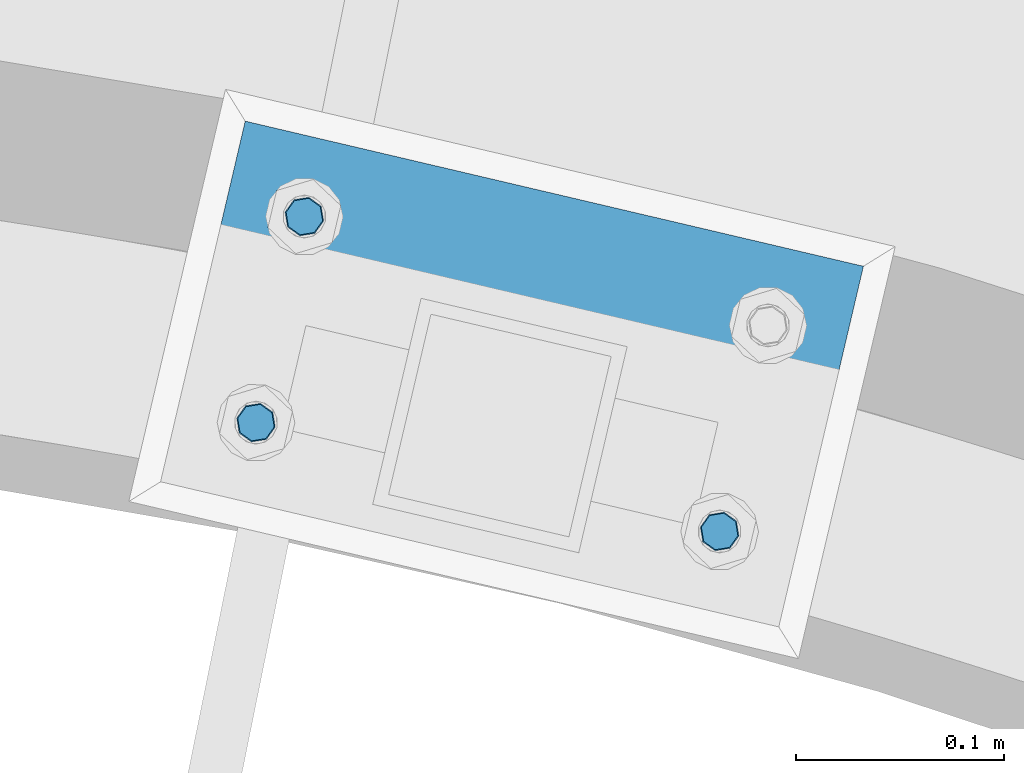
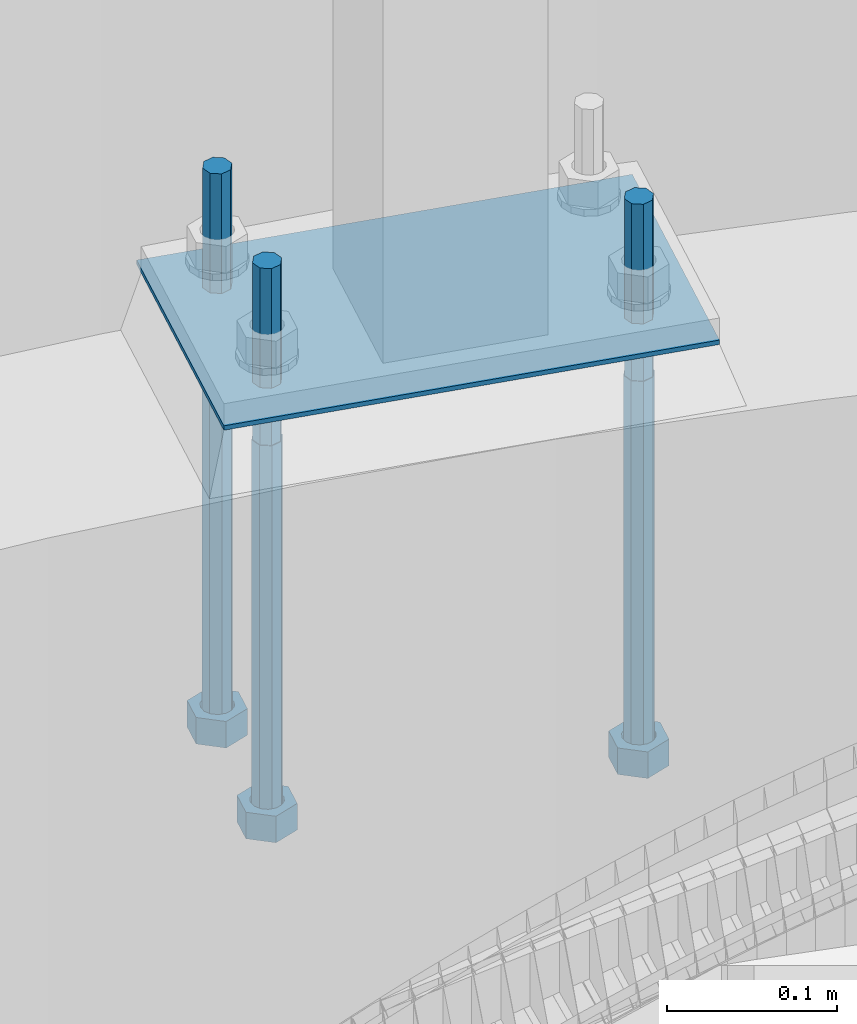
# One storey, part 517 of 975: 4 beams.
"""IFC2X3 building model written with IfcOpenShell, lengths in millimetres."""

from ifc_helpers import new_model, si_unit, frame, origin_with_axes, place, context, subcontext, project, spatial, faceted_brep, material, type_object, element, save


model = new_model("IFC2X3")

# Units and contexts
model_context = context("Model", 3, precision=1e-05, world=origin_with_axes())
body_context = subcontext(model_context, "Body", "Model", "MODEL_VIEW")
ifc_project = project(units=[si_unit("LENGTHUNIT", "METRE", prefix="MILLI"), si_unit("AREAUNIT", "SQUARE_METRE"), si_unit("VOLUMEUNIT", "CUBIC_METRE"), si_unit("MASSUNIT", "GRAM", prefix="KILO"), si_unit("TIMEUNIT", "SECOND"), si_unit("PLANEANGLEUNIT", "RADIAN"), si_unit("SOLIDANGLEUNIT", "STERADIAN"), si_unit("THERMODYNAMICTEMPERATUREUNIT", "DEGREE_CELSIUS"), si_unit("LUMINOUSINTENSITYUNIT", "LUMEN")], contexts=[model_context])

# Site, building, storey
site_placement = place(None, origin_with_axes())
site = spatial("IfcSite", under=ifc_project, at=site_placement, CompositionType="ELEMENT")
building_placement = place(site_placement, origin_with_axes())
building = spatial("IfcBuilding", under=site, at=building_placement, Name="Undefined", CompositionType="ELEMENT")
storey_placement = place(building_placement, origin_with_axes())
storey = spatial("IfcBuildingStorey", under=building, at=storey_placement, Name="Undefined", CompositionType="ELEMENT", Elevation=0.0)

# Beams
ifc_material_1 = material(Name="STEEL/F1554-36")
beam_type_1 = type_object("IfcBeamType", PredefinedType="NOTDEFINED")
beam_1_placement = place(storey_placement, frame((35592.3662910119, 6558.1059971626, 1371.6), z_axis=(0.973539033329667, -0.228520788077446, 0.0), x_axis=(0.0, 0.0, -1.0)))
element("IfcBeam", 1, at=beam_1_placement, inside=storey, type_object=beam_type_1, material=ifc_material_1, Name="HEADED_ANCHOR_BOLT", context=body_context, shape_type="Brep", body=[
    faceted_brep([(260.34375, -9.13000011445183, 15.8100004195221), (260.34375, -18.2600002289691, -1.45519152283669e-11), (279.393749999999, -18.2600002289691, -1.45519152283669e-11), (279.393749999999, -9.13000011445183, 15.8100004195221), (260.34375, 9.13000011451732, 15.8100004195403), (279.393749999999, 9.13000011451732, 15.8100004195403), (260.34375, 18.2600002289728, 1.81898940354586e-11), (279.393749999999, 18.2600002289728, 1.81898940354586e-11), (260.34375, 9.13000011445547, -15.8100004195221), (279.393749999999, 9.13000011445547, -15.8100004195221), (260.34375, -9.13000011451732, -15.8100004195367), (279.393749999999, -9.13000011451732, -15.8100004195367), (260.34375, -4.47768005528269, 9.29799844174704), (260.34375, -8.06850066050174, 6.43441456486471), (260.34375, -10.0612557562381, 2.29641597050068), (260.34375, -10.0612557562454, -2.29641597051523), (260.34375, -8.06850066052721, -6.43441456487926), (260.34375, -4.47768005531907, -9.29799844175068), (260.34375, -1.81898940354586e-11, -10.319999694766), (260.34375, 4.47768005528633, -9.2979984417434), (260.34375, 8.06850066050174, -6.43441456486471), (260.34375, 10.0612557562381, -2.29641597050068), (260.34375, 10.0612557562454, 2.29641597051886), (260.34375, 8.06850066052357, 6.4344145648829), (260.34375, 4.47768005532271, 9.29799844175432), (260.34375, 2.18278728425503e-11, 10.3199996947696), (279.393749999999, 2.18278728425503e-11, 10.3199996947696), (279.393749999999, -4.47768005528269, 9.29799844174704), (279.393749999999, -8.06850066050174, 6.43441456486471), (279.393749999999, -10.0612557562381, 2.29641597050068), (279.393749999999, -10.0612557562454, -2.29641597051523), (279.393749999999, -8.06850066052721, -6.43441456487926), (279.393749999999, -4.47768005531907, -9.29799844175068), (279.393749999999, -1.81898940354586e-11, -10.319999694766), (279.393749999999, 4.47768005528633, -9.2979984417434), (279.393749999999, 8.06850066050174, -6.43441456486471), (279.393749999999, 10.0612557562381, -2.29641597050068), (279.393749999999, 10.0612557562454, 2.29641597051886), (279.393749999999, 8.06850066052357, 6.4344145648829), (279.393749999999, 4.47768005532271, 9.29799844175432), (0.0, -6.73519209080223, 6.73519209080186), (0.0, -9.52499999999964, 0.0), (279.400000000001, -9.52499999999782, -3.63797880709171e-12), (279.400000000001, -6.73519209079313, 6.73519209079313), (-9.87109982941227e-13, -1.20792265079217e-13, 9.52499961853027), (279.400000000001, 1.09139364212751e-11, 9.52499999999054), (0.0, 6.73519209080223, 6.73519209080186), (279.400000000001, 6.73519209081132, 6.73519209079677), (0.0, 9.52499999999964, 0.0), (279.400000000001, 9.52500000000146, 3.63797880709171e-12), (0.0, 6.73519209080223, -6.73519209080186), (279.400000000001, 6.73519209079677, -6.73519209079313), (2.95075507493764e-12, -1.20792265079217e-13, -9.52499961853027), (279.400000000001, -1.09139364212751e-11, -9.5249999999869), (-126.99791499542, -6.36396103070001, 6.3639610306418), (-126.99791499542, 1.81898940354586e-11, 8.99999999995271), (-126.99791499542, 6.36396103072184, 6.36396103065272), (-126.99791499542, 9.00000000004366, 1.09139364212751e-11), (-126.99791499542, 6.36396103069637, -6.3639610306418), (-126.99791499542, -1.81898940354586e-11, -8.99999999995271), (-126.99791499542, -6.36396103072184, -6.36396103064908), (-126.99791499542, -9.00000000004002, -7.27595761418343e-12), (0.0149743263646087, 6.36396103067818, -6.36396103067909), (0.0149743263646087, 0.0, -9.0), (0.0149743263646087, -6.36396103067818, -6.36396103067909), (0.0149743263987148, -8.9999995411581, -1.00796984270346e-06), (0.0149743263646087, -6.36396103067818, 6.36396103067909), (0.0149743263646087, 0.0, 9.0), (0.0149743263646087, 6.36396103067818, 6.36396103067909), (0.0149743263987148, 9.0000004588419, -1.00796984270346e-06), (0.0, -6.73519209080223, -6.73519209080186), (279.400000000001, -6.73519209080769, -6.73519209079677)], [[[0, 1, 2, 3]], [[4, 0, 3, 5]], [[6, 4, 5, 7]], [[8, 6, 7, 9]], [[10, 8, 9, 11]], [[0, 4, 6, 8, 10, 1], [12, 13, 14, 15, 16, 17, 18, 19, 20, 21, 22, 23, 24, 25]], [[12, 25, 26, 27]], [[13, 12, 27, 28]], [[14, 13, 28, 29]], [[15, 14, 29, 30]], [[16, 15, 30, 31]], [[17, 16, 31, 32]], [[18, 17, 32, 33]], [[19, 18, 33, 34]], [[20, 19, 34, 35]], [[21, 20, 35, 36]], [[22, 21, 36, 37]], [[23, 22, 37, 38]], [[24, 23, 38, 39]], [[25, 24, 39, 26]], [[9, 7, 5, 3, 2, 11], [38, 37, 36, 35, 34, 33, 32, 31, 30, 29, 28, 27, 26, 39]], [[1, 10, 11, 2]], [[40, 41, 42, 43]], [[44, 40, 43, 45]], [[46, 44, 45, 47]], [[48, 46, 47, 49]], [[50, 48, 49, 51]], [[52, 50, 51, 53]], [[54, 55, 56, 57, 58, 59, 60, 61]], [[59, 58, 62, 63]], [[60, 59, 63, 64]], [[61, 60, 64, 65]], [[54, 61, 65, 66]], [[55, 54, 66, 67]], [[56, 55, 67, 68]], [[57, 56, 68, 69]], [[58, 57, 69, 62]], [[40, 44, 46, 48, 50, 52, 70, 41], [68, 67, 66, 65, 64, 63, 62, 69]], [[41, 70, 71, 42]], [[53, 51, 49, 47, 45, 43, 42, 71]], [[70, 52, 53, 71]]]),
])
beam_2_placement = place(storey_placement, frame((35369.8152679914, 6610.34584931771, 1371.6), z_axis=(0.973539033329667, -0.228520788077446, 0.0), x_axis=(0.0, 0.0, -1.0)))
element("IfcBeam", 2, at=beam_2_placement, inside=storey, type_object=beam_type_1, material=ifc_material_1, Name="HEADED_ANCHOR_BOLT", context=body_context, shape_type="Brep", body=[
    faceted_brep([(260.34375, -9.13000011445183, 15.8100004195221), (260.34375, -18.2600002289691, -1.45519152283669e-11), (279.393749999999, -18.2600002289691, -1.45519152283669e-11), (279.393749999999, -9.13000011445183, 15.8100004195221), (260.34375, 9.13000011451732, 15.8100004195403), (279.393749999999, 9.13000011451732, 15.8100004195403), (260.34375, 18.2600002289728, 1.81898940354586e-11), (279.393749999999, 18.2600002289728, 1.81898940354586e-11), (260.34375, 9.13000011445547, -15.8100004195221), (279.393749999999, 9.13000011445547, -15.8100004195221), (260.34375, -9.13000011451732, -15.8100004195367), (279.393749999999, -9.13000011451732, -15.8100004195367), (260.34375, -4.47768005528269, 9.29799844174704), (260.34375, -8.06850066050174, 6.43441456486471), (260.34375, -10.0612557562381, 2.29641597050068), (260.34375, -10.0612557562454, -2.29641597051523), (260.34375, -8.06850066052721, -6.43441456487926), (260.34375, -4.47768005531907, -9.29799844175068), (260.34375, -1.81898940354586e-11, -10.319999694766), (260.34375, 4.47768005528633, -9.2979984417434), (260.34375, 8.06850066050174, -6.43441456486471), (260.34375, 10.0612557562381, -2.29641597050068), (260.34375, 10.0612557562454, 2.29641597051886), (260.34375, 8.06850066052357, 6.4344145648829), (260.34375, 4.47768005532271, 9.29799844175432), (260.34375, 2.18278728425503e-11, 10.3199996947696), (279.393749999999, 2.18278728425503e-11, 10.3199996947696), (279.393749999999, -4.47768005528269, 9.29799844174704), (279.393749999999, -8.06850066050174, 6.43441456486471), (279.393749999999, -10.0612557562381, 2.29641597050068), (279.393749999999, -10.0612557562454, -2.29641597051523), (279.393749999999, -8.06850066052721, -6.43441456487926), (279.393749999999, -4.47768005531907, -9.29799844175068), (279.393749999999, -1.81898940354586e-11, -10.319999694766), (279.393749999999, 4.47768005528633, -9.2979984417434), (279.393749999999, 8.06850066050174, -6.43441456486471), (279.393749999999, 10.0612557562381, -2.29641597050068), (279.393749999999, 10.0612557562454, 2.29641597051886), (279.393749999999, 8.06850066052357, 6.4344145648829), (279.393749999999, 4.47768005532271, 9.29799844175432), (0.0, -6.73519209080223, 6.73519209080186), (0.0, -9.52499999999964, 0.0), (279.400000000001, -9.52499999999782, -3.63797880709171e-12), (279.400000000001, -6.73519209079313, 6.73519209079313), (-9.87109982941227e-13, -1.20792265079217e-13, 9.52499961853027), (279.400000000001, 1.09139364212751e-11, 9.52499999999054), (0.0, 6.73519209080223, 6.73519209080186), (279.400000000001, 6.73519209081132, 6.73519209079677), (0.0, 9.52499999999964, 0.0), (279.400000000001, 9.52500000000146, 3.63797880709171e-12), (0.0, 6.73519209080223, -6.73519209080186), (279.400000000001, 6.73519209079677, -6.73519209079313), (2.95075507493764e-12, -1.20792265079217e-13, -9.52499961853027), (279.400000000001, -1.09139364212751e-11, -9.5249999999869), (-126.99791499542, -6.36396103070001, 6.3639610306418), (-126.99791499542, 1.81898940354586e-11, 8.99999999995271), (-126.99791499542, 6.36396103072184, 6.36396103065272), (-126.99791499542, 9.00000000004366, 1.09139364212751e-11), (-126.99791499542, 6.36396103069637, -6.3639610306418), (-126.99791499542, -1.81898940354586e-11, -8.99999999995271), (-126.99791499542, -6.36396103072184, -6.36396103064908), (-126.99791499542, -9.00000000004002, -7.27595761418343e-12), (0.0149743263646087, 6.36396103067818, -6.36396103067909), (0.0149743263646087, 0.0, -9.0), (0.0149743263646087, -6.36396103067818, -6.36396103067909), (0.0149743263987148, -8.9999995411581, -1.00796984270346e-06), (0.0149743263646087, -6.36396103067818, 6.36396103067909), (0.0149743263646087, 0.0, 9.0), (0.0149743263646087, 6.36396103067818, 6.36396103067909), (0.0149743263987148, 9.0000004588419, -1.00796984270346e-06), (0.0, -6.73519209080223, -6.73519209080186), (279.400000000001, -6.73519209080769, -6.73519209079677)], [[[0, 1, 2, 3]], [[4, 0, 3, 5]], [[6, 4, 5, 7]], [[8, 6, 7, 9]], [[10, 8, 9, 11]], [[0, 4, 6, 8, 10, 1], [12, 13, 14, 15, 16, 17, 18, 19, 20, 21, 22, 23, 24, 25]], [[12, 25, 26, 27]], [[13, 12, 27, 28]], [[14, 13, 28, 29]], [[15, 14, 29, 30]], [[16, 15, 30, 31]], [[17, 16, 31, 32]], [[18, 17, 32, 33]], [[19, 18, 33, 34]], [[20, 19, 34, 35]], [[21, 20, 35, 36]], [[22, 21, 36, 37]], [[23, 22, 37, 38]], [[24, 23, 38, 39]], [[25, 24, 39, 26]], [[9, 7, 5, 3, 2, 11], [38, 37, 36, 35, 34, 33, 32, 31, 30, 29, 28, 27, 26, 39]], [[1, 10, 11, 2]], [[40, 41, 42, 43]], [[44, 40, 43, 45]], [[46, 44, 45, 47]], [[48, 46, 47, 49]], [[50, 48, 49, 51]], [[52, 50, 51, 53]], [[54, 55, 56, 57, 58, 59, 60, 61]], [[59, 58, 62, 63]], [[60, 59, 63, 64]], [[61, 60, 64, 65]], [[54, 61, 65, 66]], [[55, 54, 66, 67]], [[56, 55, 67, 68]], [[57, 56, 68, 69]], [[58, 57, 69, 62]], [[40, 44, 46, 48, 50, 52, 70, 41], [68, 67, 66, 65, 64, 63, 62, 69]], [[41, 70, 71, 42]], [[53, 51, 49, 47, 45, 43, 42, 71]], [[70, 52, 53, 71]]]),
])
beam_3_placement = place(storey_placement, frame((35393.032974118, 6709.25741649909, 1371.6), z_axis=(-0.973539033329667, 0.228520788077446, 0.0), x_axis=(0.0, 0.0, -1.0)))
element("IfcBeam", 3, at=beam_3_placement, inside=storey, type_object=beam_type_1, material=ifc_material_1, Name="HEADED_ANCHOR_BOLT", context=body_context, shape_type="Brep", body=[
    faceted_brep([(260.34375, -9.13000011445183, 15.8100004195221), (260.34375, -18.2600002289691, -1.45519152283669e-11), (279.393749999999, -18.2600002289691, -1.45519152283669e-11), (279.393749999999, -9.13000011445183, 15.8100004195221), (260.34375, 9.13000011451732, 15.8100004195403), (279.393749999999, 9.13000011451732, 15.8100004195403), (260.34375, 18.2600002289728, 1.81898940354586e-11), (279.393749999999, 18.2600002289728, 1.81898940354586e-11), (260.34375, 9.13000011445547, -15.8100004195221), (279.393749999999, 9.13000011445547, -15.8100004195221), (260.34375, -9.13000011451732, -15.8100004195367), (279.393749999999, -9.13000011451732, -15.8100004195367), (260.34375, -4.47768005528269, 9.29799844174704), (260.34375, -8.06850066050174, 6.43441456486471), (260.34375, -10.0612557562381, 2.29641597050068), (260.34375, -10.0612557562454, -2.29641597051523), (260.34375, -8.06850066052721, -6.43441456487926), (260.34375, -4.47768005531907, -9.29799844175068), (260.34375, -1.81898940354586e-11, -10.319999694766), (260.34375, 4.47768005528633, -9.2979984417434), (260.34375, 8.06850066050174, -6.43441456486471), (260.34375, 10.0612557562381, -2.29641597050068), (260.34375, 10.0612557562454, 2.29641597051886), (260.34375, 8.06850066052357, 6.4344145648829), (260.34375, 4.47768005532271, 9.29799844175432), (260.34375, 2.18278728425503e-11, 10.3199996947696), (279.393749999999, 2.18278728425503e-11, 10.3199996947696), (279.393749999999, -4.47768005528269, 9.29799844174704), (279.393749999999, -8.06850066050174, 6.43441456486471), (279.393749999999, -10.0612557562381, 2.29641597050068), (279.393749999999, -10.0612557562454, -2.29641597051523), (279.393749999999, -8.06850066052721, -6.43441456487926), (279.393749999999, -4.47768005531907, -9.29799844175068), (279.393749999999, -1.81898940354586e-11, -10.319999694766), (279.393749999999, 4.47768005528633, -9.2979984417434), (279.393749999999, 8.06850066050174, -6.43441456486471), (279.393749999999, 10.0612557562381, -2.29641597050068), (279.393749999999, 10.0612557562454, 2.29641597051886), (279.393749999999, 8.06850066052357, 6.4344145648829), (279.393749999999, 4.47768005532271, 9.29799844175432), (0.0, -6.73519209080223, 6.73519209080186), (0.0, -9.52499999999964, 0.0), (279.400000000001, -9.52499999999782, -3.63797880709171e-12), (279.400000000001, -6.73519209079313, 6.73519209079313), (-9.87109982941227e-13, -1.20792265079217e-13, 9.52499961853027), (279.400000000001, 1.09139364212751e-11, 9.52499999999054), (0.0, 6.73519209080223, 6.73519209080186), (279.400000000001, 6.73519209081132, 6.73519209079677), (0.0, 9.52499999999964, 0.0), (279.400000000001, 9.52500000000146, 3.63797880709171e-12), (0.0, 6.73519209080223, -6.73519209080186), (279.400000000001, 6.73519209079677, -6.73519209079313), (2.95075507493764e-12, -1.20792265079217e-13, -9.52499961853027), (279.400000000001, -1.09139364212751e-11, -9.5249999999869), (-126.99791499542, -6.36396103070001, 6.3639610306418), (-126.99791499542, 1.81898940354586e-11, 8.99999999995271), (-126.99791499542, 6.36396103072184, 6.36396103065272), (-126.99791499542, 9.00000000004366, 1.09139364212751e-11), (-126.99791499542, 6.36396103069637, -6.3639610306418), (-126.99791499542, -1.81898940354586e-11, -8.99999999995271), (-126.99791499542, -6.36396103072184, -6.36396103064908), (-126.99791499542, -9.00000000004002, -7.27595761418343e-12), (0.0149743263646087, 6.36396103067818, -6.36396103067909), (0.0149743263646087, 0.0, -9.0), (0.0149743263646087, -6.36396103067818, -6.36396103067909), (0.0149743263987148, -8.9999995411581, -1.00796984270346e-06), (0.0149743263646087, -6.36396103067818, 6.36396103067909), (0.0149743263646087, 0.0, 9.0), (0.0149743263646087, 6.36396103067818, 6.36396103067909), (0.0149743263987148, 9.0000004588419, -1.00796984270346e-06), (0.0, -6.73519209080223, -6.73519209080186), (279.400000000001, -6.73519209080769, -6.73519209079677)], [[[0, 1, 2, 3]], [[4, 0, 3, 5]], [[6, 4, 5, 7]], [[8, 6, 7, 9]], [[10, 8, 9, 11]], [[0, 4, 6, 8, 10, 1], [12, 13, 14, 15, 16, 17, 18, 19, 20, 21, 22, 23, 24, 25]], [[12, 25, 26, 27]], [[13, 12, 27, 28]], [[14, 13, 28, 29]], [[15, 14, 29, 30]], [[16, 15, 30, 31]], [[17, 16, 31, 32]], [[18, 17, 32, 33]], [[19, 18, 33, 34]], [[20, 19, 34, 35]], [[21, 20, 35, 36]], [[22, 21, 36, 37]], [[23, 22, 37, 38]], [[24, 23, 38, 39]], [[25, 24, 39, 26]], [[9, 7, 5, 3, 2, 11], [38, 37, 36, 35, 34, 33, 32, 31, 30, 29, 28, 27, 26, 39]], [[1, 10, 11, 2]], [[40, 41, 42, 43]], [[44, 40, 43, 45]], [[46, 44, 45, 47]], [[48, 46, 47, 49]], [[50, 48, 49, 51]], [[52, 50, 51, 53]], [[54, 55, 56, 57, 58, 59, 60, 61]], [[59, 58, 62, 63]], [[60, 59, 63, 64]], [[61, 60, 64, 65]], [[54, 61, 65, 66]], [[55, 54, 66, 67]], [[56, 55, 67, 68]], [[57, 56, 68, 69]], [[58, 57, 69, 62]], [[40, 44, 46, 48, 50, 52, 70, 41], [68, 67, 66, 65, 64, 63, 62, 69]], [[41, 70, 71, 42]], [[53, 51, 49, 47, 45, 43, 42, 71]], [[70, 52, 53, 71]]]),
])
ifc_material_2 = material(Name="STEEL/A36")
beam_type_2 = type_object("IfcBeamType", PredefinedType="NOTDEFINED")
beam_4_placement = place(storey_placement, frame((35344.3322809141, 6668.50827563138, 1411.2875), z_axis=(0.228520788077446, 0.973539033329667, 0.0), x_axis=(0.973539033329667, -0.228520788077446, 0.0)))
element("IfcBeam", 4, at=beam_4_placement, inside=storey, type_object=beam_type_2, material=ifc_material_2, Name="TEMPLATE", context=body_context, shape_type="Brep", body=[
    faceted_brep([(-1.09139364212751e-11, 1.58750000000009, -88.900000000016), (3.63797880709171e-12, 1.58750000000009, 88.9000000000196), (304.800000000418, 1.58750000000009, 88.9000000003762), (304.800000000399, 1.58750000000009, -88.8999999996631), (3.63797880709171e-12, -1.58750000000009, 88.9000000000196), (304.800000000418, -1.58750000000009, 88.9000000003762), (-1.09139364212751e-11, -1.58750000000009, -88.900000000016), (304.800000000399, -1.58750000000009, -88.8999999996631)], [[[0, 1, 2, 3]], [[1, 4, 5, 2]], [[4, 6, 7, 5]], [[6, 0, 3, 7]], [[5, 7, 3, 2]], [[6, 4, 1, 0]]]),
])

save(model, "model.ifc")
